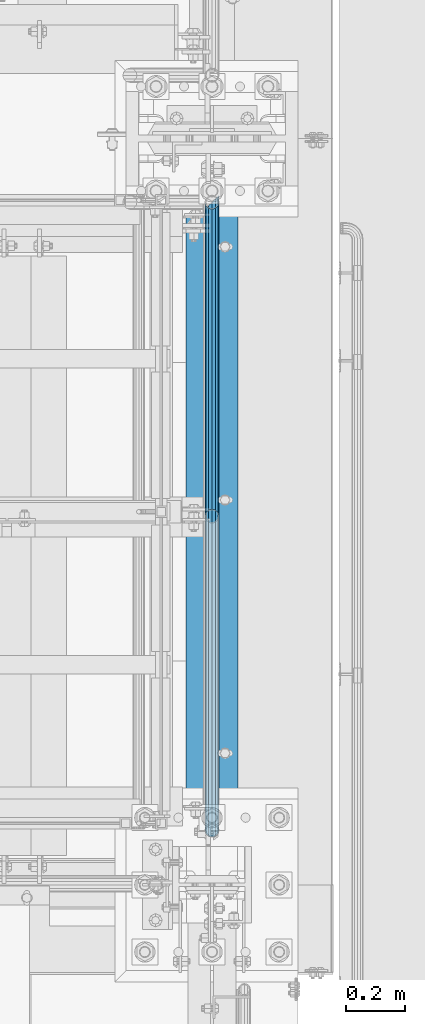
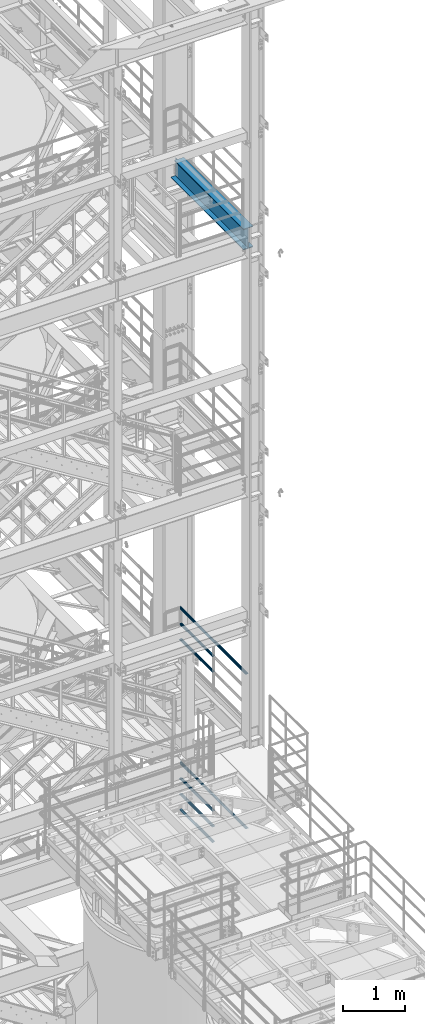
# One storey, part 1002 of 1876: 8 beams, 3 elements without a shape of their own.
"""IFC2X3 building model written with IfcOpenShell, lengths in millimetres."""

from ifc_helpers import new_model, si_unit, frame, origin_with_axes, place, context, subcontext, project, spatial, faceted_brep, material, type_object, element, aggregate, save


model = new_model("IFC2X3")

# Units and contexts
model_context = context("Model", 3, precision=1e-05, world=origin_with_axes())
body_context = subcontext(model_context, "Body", "Model", "MODEL_VIEW")
ifc_project = project(units=[si_unit("LENGTHUNIT", "METRE", prefix="MILLI"), si_unit("AREAUNIT", "SQUARE_METRE"), si_unit("VOLUMEUNIT", "CUBIC_METRE"), si_unit("MASSUNIT", "GRAM", prefix="KILO"), si_unit("TIMEUNIT", "SECOND"), si_unit("PLANEANGLEUNIT", "RADIAN"), si_unit("SOLIDANGLEUNIT", "STERADIAN"), si_unit("THERMODYNAMICTEMPERATUREUNIT", "DEGREE_CELSIUS"), si_unit("LUMINOUSINTENSITYUNIT", "LUMEN")], contexts=[model_context])

# Site, building, storey
site_placement = place(None, origin_with_axes())
site = spatial("IfcSite", under=ifc_project, at=site_placement, CompositionType="ELEMENT")
building_placement = place(site_placement, origin_with_axes())
building = spatial("IfcBuilding", under=site, at=building_placement, Name="Undefined", CompositionType="ELEMENT")
storey_placement = place(building_placement, origin_with_axes())
storey = spatial("IfcBuildingStorey", under=building, at=storey_placement, Name="Undefined", CompositionType="ELEMENT", Elevation=0.0)

# Assembly, beams
assembly_1_placement = place(storey_placement, origin_with_axes())
assembly_1 = element("IfcElementAssembly", 1, at=assembly_1_placement, inside=storey, Name="RAIL", AssemblyPlace="NOTDEFINED", PredefinedType="RIGID_FRAME")
ifc_material_1 = material()
beam_type_1 = type_object("IfcBeamType", Name="PIPE1-1/2SCH40", PredefinedType="NOTDEFINED")
beam_1_placement = place(assembly_1_placement, frame((7620.00000000001, -5857.08125, 8620.125), z_axis=(0.0, 0.0, -1.0), x_axis=(0.0, 1.0, 0.0)))
beam_1 = element("IfcBeam", 2, at=beam_1_placement, type_object=beam_type_1, material=ifc_material_1, Name="RAIL", ObjectType="PIPE1-1/2SCH40", context=body_context, shape_type="Brep", body=[
    faceted_brep([(0.0, 24.1299999999992, 0.0), (12.0650000000064, 20.8971929933177, -12.0649999999987), (12.0650000000064, 20.8971929933177, 12.0649999999987), (12.0650000000064, -20.8971929933177, 12.0649999999987), (12.0650000000064, -20.8971929933177, -12.0649999999987), (0.0, -24.1299999999992, 0.0), (20.8971929933249, -12.0650000000005, 20.8971929933177), (20.8971929933249, -12.0650000000005, 15.8661214311796), (15.2545715621445, -17.7076214311801, 10.2235000000001), (12.5151929933249, -20.4470000000001, 0.0), (15.2545715621445, -17.7076214311801, -10.2235000000001), (20.8971929933249, -12.0650000000005, -15.8661214311796), (20.8971929933249, -12.0650000000005, -20.8971929933177), (24.1300000000063, 0.0, -20.4470000000001), (24.1300000000063, 0.0, -24.130000000001), (21.3906214311868, -10.2235000000001, -17.7076214311819), (21.3906214311868, 10.2235000000001, -17.7076214311819), (20.8971929933249, 12.0650000000005, -15.8661214311796), (20.8971929933249, 12.0650000000005, -20.8971929933177), (15.2545715621445, 17.7076214311801, -10.2235000000001), (12.5151929933249, 20.4470000000001, 0.0), (15.2545715621445, 17.7076214311801, 10.2235000000001), (20.8971929933249, 12.0650000000005, 15.8661214311796), (20.8971929933249, 12.0650000000005, 20.8971929933177), (21.3906214311868, 10.2235000000001, 17.7076214311819), (24.1300000000064, 0.0, 20.4470000000001), (24.1300000000064, 0.0, 24.130000000001), (21.3906214311868, -10.2235000000001, 17.7076214311819), (1068.86375, 24.1300000000001, 0.0), (1056.79875, 20.8971929933186, -12.0649999999987), (1047.96655700668, 12.0649999999996, -20.8971929933177), (1068.86375, -24.1299999999792, 0.0), (1056.79875, -20.8971929933186, -12.0649999999987), (1056.79875, -20.8971929933186, 12.0649999999987), (1047.96655700668, -12.0649999999996, 20.8971929933177), (1047.96655700668, -12.0649999999996, -20.8971929933177), (1044.73375, 0.0, -24.130000000001), (1047.47312856881, 10.2235000000001, -17.7076214311819), (1044.73375, 0.0, -20.4470000000001), (1047.96655700668, 12.0650000000205, -15.8661214311578), (1047.96655700668, -12.0649999999787, -15.8661214312015), (1047.47312856882, -10.2235000000001, -17.7076214311819), (1053.60917843788, -17.7076214311801, -10.2235000000001), (1056.3485570067, -20.4470000000001, 0.0), (1053.60917843788, -17.7076214311801, 10.2235000000001), (1047.96655700668, -12.0649999999787, 15.8661214312015), (1047.47312856882, -10.2235000000001, 17.7076214311819), (1044.73375, 9.09494701772928e-13, 20.4470000000001), (1044.73375, 9.09494701772928e-13, 24.130000000001), (1047.96655700668, 12.0649999999996, 20.8971929933177), (1056.79875, 20.8971929933186, 12.0649999999987), (1047.96655700668, 12.0650000000205, 15.8661214311578), (1053.60917843784, 17.7076214311801, 10.2235000000001), (1056.34855700666, 20.4470000000001, 0.0), (1053.60917843784, 17.7076214311801, -10.2235000000001), (1047.47312856881, 10.2235000000001, 17.7076214311819)], [[[0, 1, 2]], [[3, 4, 5]], [[6, 7, 8, 9, 10, 11, 12, 4, 3]], [[13, 14, 12, 11, 15]], [[16, 17, 18, 14, 13]], [[2, 1, 18, 17, 19, 20, 21, 22, 23]], [[23, 22, 24, 25, 26]], [[26, 25, 27, 7, 6]], [[1, 0, 28, 29]], [[18, 1, 29, 30]], [[31, 32, 33]], [[6, 3, 33, 34]], [[3, 5, 31, 33]], [[5, 4, 32, 31]], [[4, 12, 35, 32]], [[12, 14, 36, 35]], [[14, 18, 30, 36]], [[37, 38, 36, 30, 39]], [[40, 35, 36, 38, 41]], [[33, 32, 35, 40, 42, 43, 44, 45, 34]], [[34, 45, 46, 47, 48]], [[26, 6, 34, 48]], [[2, 23, 49, 50]], [[23, 26, 48, 49]], [[0, 2, 50, 28]], [[28, 50, 29]], [[49, 51, 52, 53, 54, 39, 30, 29, 50]], [[48, 47, 55, 51, 49]], [[25, 24, 55, 47]], [[55, 24, 22, 21, 52, 51]], [[21, 20, 53, 52]], [[20, 19, 54, 53]], [[19, 17, 16, 37, 39, 54]], [[16, 13, 38, 37]], [[13, 15, 41, 38]], [[41, 15, 11, 10, 42, 40]], [[10, 9, 43, 42]], [[9, 8, 44, 43]], [[8, 7, 27, 46, 45, 44]], [[27, 25, 47, 46]]]),
])
beam_2_placement = place(assembly_1_placement, frame((7620.00000000001, -5857.08125, 8924.925), z_axis=(0.0, 0.0, -1.0), x_axis=(0.0, 1.0, 0.0)))
beam_2 = element("IfcBeam", 3, at=beam_2_placement, type_object=beam_type_1, material=ifc_material_1, Name="RAIL", ObjectType="PIPE1-1/2SCH40", context=body_context, shape_type="Brep", body=[
    faceted_brep([(0.0, 24.1299999999992, 0.0), (12.0650000000064, 20.8971929933177, -12.0649999999987), (12.0650000000064, 20.8971929933177, 12.0649999999987), (12.0650000000064, -20.8971929933177, 12.0649999999987), (12.0650000000064, -20.8971929933177, -12.0649999999987), (0.0, -24.1299999999992, 0.0), (20.8971929933249, -12.0650000000005, 20.8971929933177), (20.8971929933249, -12.0650000000005, 15.8661214311796), (15.2545715621445, -17.7076214311801, 10.2235000000001), (12.5151929933249, -20.4470000000001, 0.0), (15.2545715621445, -17.7076214311801, -10.2235000000001), (20.8971929933249, -12.0650000000005, -15.8661214311796), (20.8971929933249, -12.0650000000005, -20.8971929933177), (24.1300000000063, 0.0, -20.4470000000001), (24.1300000000063, 0.0, -24.130000000001), (21.3906214311868, -10.2235000000001, -17.7076214311819), (21.3906214311868, 10.2235000000001, -17.7076214311819), (20.8971929933249, 12.0650000000005, -15.8661214311796), (20.8971929933249, 12.0650000000005, -20.8971929933177), (15.2545715621445, 17.7076214311801, -10.2235000000001), (12.5151929933249, 20.4470000000001, 0.0), (15.2545715621445, 17.7076214311801, 10.2235000000001), (20.8971929933249, 12.0650000000005, 15.8661214311796), (20.8971929933249, 12.0650000000005, 20.8971929933177), (21.3906214311868, 10.2235000000001, 17.7076214311819), (24.1300000000064, 0.0, 20.4470000000001), (24.1300000000064, 0.0, 24.130000000001), (21.3906214311868, -10.2235000000001, 17.7076214311819), (1068.86375, 24.1300000000001, 0.0), (1056.79875, 20.8971929933186, -12.0649999999987), (1047.96655700668, 12.0649999999996, -20.8971929933177), (1068.86375, -24.1299999999792, 0.0), (1056.79875, -20.8971929933186, -12.0649999999987), (1056.79875, -20.8971929933186, 12.0649999999987), (1047.96655700668, -12.0649999999996, 20.8971929933177), (1047.96655700668, -12.0649999999996, -20.8971929933177), (1044.73375, 0.0, -24.130000000001), (1047.47312856881, 10.2235000000001, -17.7076214311819), (1044.73375, 0.0, -20.4470000000001), (1047.96655700668, 12.0650000000205, -15.8661214311578), (1047.96655700668, -12.0649999999787, -15.8661214312015), (1047.47312856882, -10.2235000000001, -17.7076214311819), (1053.60917843788, -17.7076214311801, -10.2235000000001), (1056.3485570067, -20.4470000000001, 0.0), (1053.60917843788, -17.7076214311801, 10.2235000000001), (1047.96655700668, -12.0649999999787, 15.8661214312015), (1047.47312856882, -10.2235000000001, 17.7076214311819), (1044.73375, 9.09494701772928e-13, 20.4470000000001), (1044.73375, 9.09494701772928e-13, 24.130000000001), (1047.96655700668, 12.0649999999996, 20.8971929933177), (1056.79875, 20.8971929933186, 12.0649999999987), (1047.96655700668, 12.0650000000205, 15.8661214311578), (1053.60917843784, 17.7076214311801, 10.2235000000001), (1056.34855700666, 20.4470000000001, 0.0), (1053.60917843784, 17.7076214311801, -10.2235000000001), (1047.47312856881, 10.2235000000001, 17.7076214311819)], [[[0, 1, 2]], [[3, 4, 5]], [[6, 7, 8, 9, 10, 11, 12, 4, 3]], [[13, 14, 12, 11, 15]], [[16, 17, 18, 14, 13]], [[2, 1, 18, 17, 19, 20, 21, 22, 23]], [[23, 22, 24, 25, 26]], [[26, 25, 27, 7, 6]], [[1, 0, 28, 29]], [[18, 1, 29, 30]], [[31, 32, 33]], [[6, 3, 33, 34]], [[3, 5, 31, 33]], [[5, 4, 32, 31]], [[4, 12, 35, 32]], [[12, 14, 36, 35]], [[14, 18, 30, 36]], [[37, 38, 36, 30, 39]], [[40, 35, 36, 38, 41]], [[33, 32, 35, 40, 42, 43, 44, 45, 34]], [[34, 45, 46, 47, 48]], [[26, 6, 34, 48]], [[2, 23, 49, 50]], [[23, 26, 48, 49]], [[0, 2, 50, 28]], [[28, 50, 29]], [[49, 51, 52, 53, 54, 39, 30, 29, 50]], [[48, 47, 55, 51, 49]], [[25, 24, 55, 47]], [[55, 24, 22, 21, 52, 51]], [[21, 20, 53, 52]], [[20, 19, 54, 53]], [[19, 17, 16, 37, 39, 54]], [[16, 13, 38, 37]], [[13, 15, 41, 38]], [[41, 15, 11, 10, 42, 40]], [[10, 9, 43, 42]], [[9, 8, 44, 43]], [[8, 7, 27, 46, 45, 44]], [[27, 25, 47, 46]]]),
])
beam_3_placement = place(assembly_1_placement, frame((7620.00000000001, -6950.075, 9229.725), z_axis=(0.0, 0.0, -1.0), x_axis=(0.0, 1.0, 0.0)))
beam_3 = element("IfcBeam", 4, at=beam_3_placement, type_object=beam_type_1, material=ifc_material_1, Name="RAIL", ObjectType="PIPE1-1/2SCH40", context=body_context, shape_type="Brep", body=[
    faceted_brep([(24.1300000000001, -20.4469999999999, 0.0), (34.3535000000002, -17.7076214311803, 10.2235000000001), (2144.14987856882, -17.7076214311801, 10.2235000000001), (2141.4105, -20.4470000000001, 0.0), (41.8376214311802, -10.2235000000001, 17.7076214311819), (2151.634, -10.2235000000001, 17.7076214311819), (44.5770000000002, 0.0, 20.4470000000001), (2161.8575, 0.0, 20.4470000000001), (41.8376214311802, 10.2235000000001, 17.7076214311819), (2172.081, 10.2235000000001, 17.7076214311819), (34.3535000000002, 17.7076214311803, 10.2235000000001), (2179.56512143118, 17.7076214311801, 10.2235000000001), (24.1300000000001, 20.4469999999999, 0.0), (2182.3045, 20.4470000000001, 0.0), (13.9065000000001, 17.7076214311803, -10.2235000000001), (2179.56512143118, 17.7076214311801, -10.2235000000001), (6.42237856882002, 10.2235000000001, -17.7076214311819), (2172.081, 10.2235000000001, -17.7076214311819), (3.68299999999999, 0.0, -20.4470000000001), (2161.8575, 0.0, -20.4470000000001), (6.42237856882002, -10.2235000000001, -17.7076214311819), (2151.634, -10.2235000000001, -17.7076214311819), (13.9065000000001, -17.7076214311803, -10.2235000000001), (2144.14987856882, -17.7076214311801, -10.2235000000001), (24.1299999999854, -24.1299999999992, 0.0), (12.0650000000064, -20.8971929933177, -12.0649999999987), (2140.96030700668, -20.8971929933186, -12.0649999999987), (2137.7275, -24.1300000000001, 0.0), (3.23280700668147, -12.0650000000001, -20.8971929933177), (2149.7925, -12.0649999999996, -20.8971929933177), (-1.45519152283669e-11, 0.0, -24.130000000001), (2161.8575, 0.0, -24.130000000001), (3.23280700668147, 12.0650000000001, -20.8971929933177), (2173.9225, 12.0649999999996, -20.8971929933177), (12.0650000000064, 20.8971929933177, -12.0649999999987), (2182.75469299332, 20.8971929933186, -12.0649999999987), (24.1300000000047, 24.1299999999992, 0.0), (2185.9875, 24.1300000000001, 0.0), (36.1949999999997, 20.8971929933184, 12.0649999999987), (2182.75469299332, 20.8971929933186, 12.0649999999987), (45.0271929933187, 12.0650000000001, 20.8971929933177), (2173.9225, 12.0649999999996, 20.8971929933177), (48.2600000000002, 0.0, 24.130000000001), (2161.8575, 0.0, 24.130000000001), (45.0271929933187, -12.0650000000001, 20.8971929933177), (2149.7925, -12.0649999999996, 20.8971929933177), (36.1949999999997, -20.8971929933184, 12.0649999999987), (2140.96030700668, -20.8971929933186, 12.0649999999987)], [[[0, 1, 2, 3]], [[1, 4, 5, 2]], [[4, 6, 7, 5]], [[6, 8, 9, 7]], [[8, 10, 11, 9]], [[10, 12, 13, 11]], [[12, 14, 15, 13]], [[14, 16, 17, 15]], [[16, 18, 19, 17]], [[18, 20, 21, 19]], [[20, 22, 23, 21]], [[22, 0, 3, 23]], [[24, 25, 26, 27]], [[25, 28, 29, 26]], [[28, 30, 31, 29]], [[30, 32, 33, 31]], [[32, 34, 35, 33]], [[34, 36, 37, 35]], [[36, 38, 39, 37]], [[38, 40, 41, 39]], [[40, 42, 43, 41]], [[42, 44, 45, 43]], [[44, 46, 47, 45]], [[46, 24, 27, 47]], [[29, 31, 33, 35, 37, 39, 41, 43, 45, 47, 27, 26], [5, 7, 9, 11, 13, 15, 17, 19, 21, 23, 3, 2]], [[46, 44, 42, 40, 38, 36, 34, 32, 30, 28, 25, 24], [22, 20, 18, 16, 14, 12, 10, 8, 6, 4, 1, 0]]]),
])
aggregate(assembly_1, [beam_1, beam_2, beam_3])

assembly_2_placement = place(storey_placement, origin_with_axes())
assembly_2 = element("IfcElementAssembly", 5, at=assembly_2_placement, inside=storey, Name="RAIL", AssemblyPlace="NOTDEFINED", PredefinedType="RIGID_FRAME")
beam_4_placement = place(assembly_2_placement, frame((7620.0, -4788.2175, 5292.725), z_axis=(0.0, 0.0, 1.0), x_axis=(0.0, -1.0, 0.0)))
beam_4 = element("IfcBeam", 6, at=beam_4_placement, type_object=beam_type_1, material=ifc_material_1, Name="RAIL", ObjectType="PIPE1-1/2SCH40", context=body_context, shape_type="Brep", body=[
    faceted_brep([(1047.96655700668, -12.0649999999996, 20.8971929933177), (1047.96655700668, -12.0649999999787, 15.8661214312015), (1047.47312856882, -10.2235000000001, 17.7076214311819), (1044.73375, 9.09494701772928e-13, 20.4470000000001), (1044.73375, 9.09494701772928e-13, 24.130000000001), (1047.47312856881, 10.2235000000001, 17.7076214311819), (1047.96655700668, 12.0650000000205, 15.8661214311578), (1047.96655700668, 12.0649999999996, 20.8971929933177), (1068.86375, 24.1300000000001, 0.0), (1056.79875, 20.8971929933186, 12.0649999999987), (1056.79875, 20.8971929933186, -12.0649999999987), (1053.60917843784, 17.7076214311801, 10.2235000000001), (1056.34855700666, 20.4470000000001, 0.0), (1053.60917843784, 17.7076214311801, -10.2235000000001), (1047.96655700668, 12.0650000000205, -15.8661214311578), (1047.96655700668, 12.0649999999996, -20.8971929933177), (1047.47312856881, 10.2235000000001, -17.7076214311819), (1044.73375, 0.0, -20.4470000000001), (1044.73375, 0.0, -24.130000000001), (1047.96655700668, -12.0649999999787, -15.8661214312015), (1047.96655700668, -12.0649999999996, -20.8971929933177), (1047.47312856882, -10.2235000000001, -17.7076214311819), (1068.86375, -24.1299999999792, 0.0), (1056.79875, -20.8971929933186, -12.0649999999987), (1056.79875, -20.8971929933186, 12.0649999999987), (1053.60917843788, -17.7076214311801, -10.2235000000001), (1056.3485570067, -20.4470000000001, 0.0), (1053.60917843788, -17.7076214311801, 10.2235000000001), (12.0650000000064, -20.8971929933177, -12.0649999999987), (20.8971929933249, -12.0650000000005, -20.8971929933177), (0.0, 24.1299999999992, 0.0), (12.0650000000064, 20.8971929933177, -12.0649999999987), (12.0650000000064, 20.8971929933177, 12.0649999999987), (20.8971929933249, 12.0650000000005, 20.8971929933177), (24.1300000000064, 0.0, 24.130000000001), (20.8971929933249, 12.0650000000005, -20.8971929933177), (24.1300000000063, 0.0, -24.130000000001), (24.1300000000063, 0.0, -20.4470000000001), (20.8971929933249, -12.0650000000005, -15.8661214311796), (21.3906214311868, -10.2235000000001, -17.7076214311819), (21.3906214311868, 10.2235000000001, -17.7076214311819), (20.8971929933249, 12.0650000000005, -15.8661214311796), (15.2545715621445, 17.7076214311801, -10.2235000000001), (12.5151929933249, 20.4470000000001, 0.0), (15.2545715621445, 17.7076214311801, 10.2235000000001), (20.8971929933249, 12.0650000000005, 15.8661214311796), (21.3906214311868, 10.2235000000001, 17.7076214311819), (24.1300000000064, 0.0, 20.4470000000001), (21.3906214311868, -10.2235000000001, 17.7076214311819), (20.8971929933249, -12.0650000000005, 15.8661214311796), (20.8971929933249, -12.0650000000005, 20.8971929933177), (12.0650000000064, -20.8971929933177, 12.0649999999987), (0.0, -24.1299999999992, 0.0), (15.2545715621445, -17.7076214311801, 10.2235000000001), (12.5151929933249, -20.4470000000001, 0.0), (15.2545715621445, -17.7076214311801, -10.2235000000001)], [[[0, 1, 2, 3, 4]], [[4, 3, 5, 6, 7]], [[8, 9, 10]], [[7, 6, 11, 12, 13, 14, 15, 10, 9]], [[16, 17, 18, 15, 14]], [[19, 20, 18, 17, 21]], [[22, 23, 24]], [[24, 23, 20, 19, 25, 26, 27, 1, 0]], [[28, 29, 20, 23]], [[30, 31, 32]], [[33, 34, 4, 7]], [[32, 33, 7, 9]], [[30, 32, 9, 8]], [[31, 30, 8, 10]], [[35, 31, 10, 15]], [[36, 35, 15, 18]], [[29, 36, 18, 20]], [[37, 36, 29, 38, 39]], [[40, 41, 35, 36, 37]], [[32, 31, 35, 41, 42, 43, 44, 45, 33]], [[33, 45, 46, 47, 34]], [[34, 47, 48, 49, 50]], [[34, 50, 0, 4]], [[50, 51, 24, 0]], [[51, 52, 22, 24]], [[52, 28, 23, 22]], [[51, 28, 52]], [[50, 49, 53, 54, 55, 38, 29, 28, 51]], [[55, 54, 26, 25]], [[21, 39, 38, 55, 25, 19]], [[37, 39, 21, 17]], [[40, 37, 17, 16]], [[42, 41, 40, 16, 14, 13]], [[43, 42, 13, 12]], [[44, 43, 12, 11]], [[5, 46, 45, 44, 11, 6]], [[47, 46, 5, 3]], [[48, 47, 3, 2]], [[53, 49, 48, 2, 1, 27]], [[54, 53, 27, 26]]]),
])
beam_5_placement = place(assembly_2_placement, frame((7619.99999999923, -5857.08125, 5597.52500110399), z_axis=(0.0, 0.0, -1.0), x_axis=(0.0, 1.0, 0.0)))
beam_5 = element("IfcBeam", 7, at=beam_5_placement, type_object=beam_type_1, material=ifc_material_1, Name="RAIL", ObjectType="PIPE1-1/2SCH40", context=body_context, shape_type="Brep", body=[
    faceted_brep([(0.0, 24.1299999999992, 0.0), (12.0650000000064, 20.8971929933177, -12.0649999999987), (12.0650000000064, 20.8971929933177, 12.0649999999987), (12.0650000000064, -20.8971929933177, 12.0649999999987), (12.0650000000064, -20.8971929933177, -12.0649999999987), (0.0, -24.1299999999992, 0.0), (20.8971929933249, -12.0650000000005, 20.8971929933177), (20.8971929933249, -12.0650000000005, 15.8661214311796), (15.2545715621445, -17.7076214311801, 10.2235000000001), (12.5151929933249, -20.4470000000001, 0.0), (15.2545715621445, -17.7076214311801, -10.2235000000001), (20.8971929933249, -12.0650000000005, -15.8661214311796), (20.8971929933249, -12.0650000000005, -20.8971929933177), (24.1300000000063, 0.0, -20.4470000000001), (24.1300000000063, 0.0, -24.130000000001), (21.3906214311868, -10.2235000000001, -17.7076214311819), (21.3906214311868, 10.2235000000001, -17.7076214311819), (20.8971929933249, 12.0650000000005, -15.8661214311796), (20.8971929933249, 12.0650000000005, -20.8971929933177), (15.2545715621445, 17.7076214311801, -10.2235000000001), (12.5151929933249, 20.4470000000001, 0.0), (15.2545715621445, 17.7076214311801, 10.2235000000001), (20.8971929933249, 12.0650000000005, 15.8661214311796), (20.8971929933249, 12.0650000000005, 20.8971929933177), (21.3906214311868, 10.2235000000001, 17.7076214311819), (24.1300000000064, 0.0, 20.4470000000001), (24.1300000000064, 0.0, 24.130000000001), (21.3906214311868, -10.2235000000001, 17.7076214311819), (1068.86375, 24.1300000000001, 0.0), (1056.79875, 20.8971929933186, -12.0649999999987), (1047.96655700668, 12.0649999999996, -20.8971929933177), (1068.86375, -24.1299999999792, 0.0), (1056.79875, -20.8971929933186, -12.0649999999987), (1056.79875, -20.8971929933186, 12.0649999999987), (1047.96655700668, -12.0649999999996, 20.8971929933177), (1047.96655700668, -12.0649999999996, -20.8971929933177), (1044.73375, 0.0, -24.130000000001), (1047.47312856881, 10.2235000000001, -17.7076214311819), (1044.73375, 0.0, -20.4470000000001), (1047.96655700668, 12.0650000000205, -15.8661214311578), (1047.96655700668, -12.0649999999787, -15.8661214312015), (1047.47312856882, -10.2235000000001, -17.7076214311819), (1053.60917843788, -17.7076214311801, -10.2235000000001), (1056.3485570067, -20.4470000000001, 0.0), (1053.60917843788, -17.7076214311801, 10.2235000000001), (1047.96655700668, -12.0649999999787, 15.8661214312015), (1047.47312856882, -10.2235000000001, 17.7076214311819), (1044.73375, 9.09494701772928e-13, 20.4470000000001), (1044.73375, 9.09494701772928e-13, 24.130000000001), (1047.96655700668, 12.0649999999996, 20.8971929933177), (1056.79875, 20.8971929933186, 12.0649999999987), (1047.96655700668, 12.0650000000205, 15.8661214311578), (1053.60917843784, 17.7076214311801, 10.2235000000001), (1056.34855700666, 20.4470000000001, 0.0), (1053.60917843784, 17.7076214311801, -10.2235000000001), (1047.47312856881, 10.2235000000001, 17.7076214311819)], [[[0, 1, 2]], [[3, 4, 5]], [[6, 7, 8, 9, 10, 11, 12, 4, 3]], [[13, 14, 12, 11, 15]], [[16, 17, 18, 14, 13]], [[2, 1, 18, 17, 19, 20, 21, 22, 23]], [[23, 22, 24, 25, 26]], [[26, 25, 27, 7, 6]], [[1, 0, 28, 29]], [[18, 1, 29, 30]], [[31, 32, 33]], [[6, 3, 33, 34]], [[3, 5, 31, 33]], [[5, 4, 32, 31]], [[4, 12, 35, 32]], [[12, 14, 36, 35]], [[14, 18, 30, 36]], [[37, 38, 36, 30, 39]], [[40, 35, 36, 38, 41]], [[33, 32, 35, 40, 42, 43, 44, 45, 34]], [[34, 45, 46, 47, 48]], [[26, 6, 34, 48]], [[2, 23, 49, 50]], [[23, 26, 48, 49]], [[0, 2, 50, 28]], [[28, 50, 29]], [[49, 51, 52, 53, 54, 39, 30, 29, 50]], [[48, 47, 55, 51, 49]], [[25, 24, 55, 47]], [[55, 24, 22, 21, 52, 51]], [[21, 20, 53, 52]], [[20, 19, 54, 53]], [[19, 17, 16, 37, 39, 54]], [[16, 13, 38, 37]], [[13, 15, 41, 38]], [[41, 15, 11, 10, 42, 40]], [[10, 9, 43, 42]], [[9, 8, 44, 43]], [[8, 7, 27, 46, 45, 44]], [[27, 25, 47, 46]]]),
])
beam_6_placement = place(assembly_2_placement, frame((7619.99999999959, -5857.08125, 5902.32500110437), z_axis=(0.0, 0.0, -1.0), x_axis=(0.0, 1.0, 0.0)))
beam_6 = element("IfcBeam", 8, at=beam_6_placement, type_object=beam_type_1, material=ifc_material_1, Name="RAIL", ObjectType="PIPE1-1/2SCH40", context=body_context, shape_type="Brep", body=[
    faceted_brep([(0.0, 24.1299999999992, 0.0), (12.0650000000064, 20.8971929933177, -12.0649999999987), (12.0650000000064, 20.8971929933177, 12.0649999999987), (12.0650000000064, -20.8971929933177, 12.0649999999987), (12.0650000000064, -20.8971929933177, -12.0649999999987), (0.0, -24.1299999999992, 0.0), (20.8971929933249, -12.0650000000005, 20.8971929933177), (20.8971929933249, -12.0650000000005, 15.8661214311796), (15.2545715621445, -17.7076214311801, 10.2235000000001), (12.5151929933249, -20.4470000000001, 0.0), (15.2545715621445, -17.7076214311801, -10.2235000000001), (20.8971929933249, -12.0650000000005, -15.8661214311796), (20.8971929933249, -12.0650000000005, -20.8971929933177), (24.1300000000063, 0.0, -20.4470000000001), (24.1300000000063, 0.0, -24.130000000001), (21.3906214311868, -10.2235000000001, -17.7076214311819), (21.3906214311868, 10.2235000000001, -17.7076214311819), (20.8971929933249, 12.0650000000005, -15.8661214311796), (20.8971929933249, 12.0650000000005, -20.8971929933177), (15.2545715621445, 17.7076214311801, -10.2235000000001), (12.5151929933249, 20.4470000000001, 0.0), (15.2545715621445, 17.7076214311801, 10.2235000000001), (20.8971929933249, 12.0650000000005, 15.8661214311796), (20.8971929933249, 12.0650000000005, 20.8971929933177), (21.3906214311868, 10.2235000000001, 17.7076214311819), (24.1300000000064, 0.0, 20.4470000000001), (24.1300000000064, 0.0, 24.130000000001), (21.3906214311868, -10.2235000000001, 17.7076214311819), (1068.86375, 24.1300000000001, 0.0), (1056.79875, 20.8971929933186, -12.0649999999987), (1047.96655700668, 12.0649999999996, -20.8971929933177), (1068.86375, -24.1299999999792, 0.0), (1056.79875, -20.8971929933186, -12.0649999999987), (1056.79875, -20.8971929933186, 12.0649999999987), (1047.96655700668, -12.0649999999996, 20.8971929933177), (1047.96655700668, -12.0649999999996, -20.8971929933177), (1044.73375, 0.0, -24.130000000001), (1047.47312856881, 10.2235000000001, -17.7076214311819), (1044.73375, 0.0, -20.4470000000001), (1047.96655700668, 12.0650000000205, -15.8661214311578), (1047.96655700668, -12.0649999999787, -15.8661214312015), (1047.47312856882, -10.2235000000001, -17.7076214311819), (1053.60917843788, -17.7076214311801, -10.2235000000001), (1056.3485570067, -20.4470000000001, 0.0), (1053.60917843788, -17.7076214311801, 10.2235000000001), (1047.96655700668, -12.0649999999787, 15.8661214312015), (1047.47312856882, -10.2235000000001, 17.7076214311819), (1044.73375, 9.09494701772928e-13, 20.4470000000001), (1044.73375, 9.09494701772928e-13, 24.130000000001), (1047.96655700668, 12.0649999999996, 20.8971929933177), (1056.79875, 20.8971929933186, 12.0649999999987), (1047.96655700668, 12.0650000000205, 15.8661214311578), (1053.60917843784, 17.7076214311801, 10.2235000000001), (1056.34855700666, 20.4470000000001, 0.0), (1053.60917843784, 17.7076214311801, -10.2235000000001), (1047.47312856881, 10.2235000000001, 17.7076214311819)], [[[0, 1, 2]], [[3, 4, 5]], [[6, 7, 8, 9, 10, 11, 12, 4, 3]], [[13, 14, 12, 11, 15]], [[16, 17, 18, 14, 13]], [[2, 1, 18, 17, 19, 20, 21, 22, 23]], [[23, 22, 24, 25, 26]], [[26, 25, 27, 7, 6]], [[1, 0, 28, 29]], [[18, 1, 29, 30]], [[31, 32, 33]], [[6, 3, 33, 34]], [[3, 5, 31, 33]], [[5, 4, 32, 31]], [[4, 12, 35, 32]], [[12, 14, 36, 35]], [[14, 18, 30, 36]], [[37, 38, 36, 30, 39]], [[40, 35, 36, 38, 41]], [[33, 32, 35, 40, 42, 43, 44, 45, 34]], [[34, 45, 46, 47, 48]], [[26, 6, 34, 48]], [[2, 23, 49, 50]], [[23, 26, 48, 49]], [[0, 2, 50, 28]], [[28, 50, 29]], [[49, 51, 52, 53, 54, 39, 30, 29, 50]], [[48, 47, 55, 51, 49]], [[25, 24, 55, 47]], [[55, 24, 22, 21, 52, 51]], [[21, 20, 53, 52]], [[20, 19, 54, 53]], [[19, 17, 16, 37, 39, 54]], [[16, 13, 38, 37]], [[13, 15, 41, 38]], [[41, 15, 11, 10, 42, 40]], [[10, 9, 43, 42]], [[9, 8, 44, 43]], [[8, 7, 27, 46, 45, 44]], [[27, 25, 47, 46]]]),
])
beam_7_placement = place(assembly_2_placement, frame((7620.00000000063, -6950.07500000001, 6207.12499997672), z_axis=(0.0, 0.0, -1.0), x_axis=(0.0, 1.0, 0.0)))
beam_7 = element("IfcBeam", 9, at=beam_7_placement, type_object=beam_type_1, material=ifc_material_1, Name="RAIL", ObjectType="PIPE1-1/2SCH40", context=body_context, shape_type="Brep", body=[
    faceted_brep([(24.1300000000001, -20.4469999999999, 0.0), (34.3535000000002, -17.7076214311803, 10.2235000000001), (2144.14987856882, -17.7076214311801, 10.2235000000001), (2141.4105, -20.4470000000001, 0.0), (41.8376214311802, -10.2235000000001, 17.7076214311819), (2151.634, -10.2235000000001, 17.7076214311819), (44.5770000000002, 0.0, 20.4470000000001), (2161.8575, 0.0, 20.4470000000001), (41.8376214311802, 10.2235000000001, 17.7076214311819), (2172.081, 10.2235000000001, 17.7076214311819), (34.3535000000002, 17.7076214311803, 10.2235000000001), (2179.56512143118, 17.7076214311801, 10.2235000000001), (24.1300000000001, 20.4469999999999, 0.0), (2182.3045, 20.4470000000001, 0.0), (13.9065000000001, 17.7076214311803, -10.2235000000001), (2179.56512143118, 17.7076214311801, -10.2235000000001), (6.42237856882002, 10.2235000000001, -17.7076214311819), (2172.081, 10.2235000000001, -17.7076214311819), (3.68299999999999, 0.0, -20.4470000000001), (2161.8575, 0.0, -20.4470000000001), (6.42237856882002, -10.2235000000001, -17.7076214311819), (2151.634, -10.2235000000001, -17.7076214311819), (13.9065000000001, -17.7076214311803, -10.2235000000001), (2144.14987856882, -17.7076214311801, -10.2235000000001), (24.1299999999854, -24.1299999999992, 0.0), (12.0650000000064, -20.8971929933177, -12.0649999999987), (2140.96030700668, -20.8971929933186, -12.0649999999987), (2137.7275, -24.1300000000001, 0.0), (3.23280700668147, -12.0650000000001, -20.8971929933177), (2149.7925, -12.0649999999996, -20.8971929933177), (-1.45519152283669e-11, 0.0, -24.130000000001), (2161.8575, 0.0, -24.130000000001), (3.23280700668147, 12.0650000000001, -20.8971929933177), (2173.9225, 12.0649999999996, -20.8971929933177), (12.0650000000064, 20.8971929933177, -12.0649999999987), (2182.75469299332, 20.8971929933186, -12.0649999999987), (24.1300000000047, 24.1299999999992, 0.0), (2185.9875, 24.1300000000001, 0.0), (36.1949999999997, 20.8971929933184, 12.0649999999987), (2182.75469299332, 20.8971929933186, 12.0649999999987), (45.0271929933187, 12.0650000000001, 20.8971929933177), (2173.9225, 12.0649999999996, 20.8971929933177), (48.2600000000002, 0.0, 24.130000000001), (2161.8575, 0.0, 24.130000000001), (45.0271929933187, -12.0650000000001, 20.8971929933177), (2149.7925, -12.0649999999996, 20.8971929933177), (36.1949999999997, -20.8971929933184, 12.0649999999987), (2140.96030700668, -20.8971929933186, 12.0649999999987)], [[[0, 1, 2, 3]], [[1, 4, 5, 2]], [[4, 6, 7, 5]], [[6, 8, 9, 7]], [[8, 10, 11, 9]], [[10, 12, 13, 11]], [[12, 14, 15, 13]], [[14, 16, 17, 15]], [[16, 18, 19, 17]], [[18, 20, 21, 19]], [[20, 22, 23, 21]], [[22, 0, 3, 23]], [[24, 25, 26, 27]], [[25, 28, 29, 26]], [[28, 30, 31, 29]], [[30, 32, 33, 31]], [[32, 34, 35, 33]], [[34, 36, 37, 35]], [[36, 38, 39, 37]], [[38, 40, 41, 39]], [[40, 42, 43, 41]], [[42, 44, 45, 43]], [[44, 46, 47, 45]], [[46, 24, 27, 47]], [[29, 31, 33, 35, 37, 39, 41, 43, 45, 47, 27, 26], [5, 7, 9, 11, 13, 15, 17, 19, 21, 23, 3, 2]], [[46, 44, 42, 40, 38, 36, 34, 32, 30, 28, 25, 24], [22, 20, 18, 16, 14, 12, 10, 8, 6, 4, 1, 0]]]),
])
aggregate(assembly_2, [beam_4, beam_5, beam_6, beam_7])

# Assembly, beam
assembly_3_placement = place(storey_placement, origin_with_axes())
assembly_3 = element("IfcElementAssembly", 10, at=assembly_3_placement, inside=storey, Name="BEAM", AssemblyPlace="NOTDEFINED", PredefinedType="RIGID_FRAME")
ifc_material_2 = material(Name="STEEL/A992")
beam_type_2 = type_object("IfcBeamType", Name="W16X45", PredefinedType="NOTDEFINED")
beam_8_placement = place(assembly_3_placement, frame((7620.0, -7112.0, 17778.4125), z_axis=(0.0, 0.0, 1.0), x_axis=(0.0, 1.0, 0.0)))
beam_8 = element("IfcBeam", 11, at=beam_8_placement, type_object=beam_type_2, material=ifc_material_2, Name="BEAM", ObjectType="W16X45", context=body_context, shape_type="Brep", body=[
    faceted_brep([(2362.99375, -88.8999999999996, 204.787499999999), (2362.99375, -88.8999999999996, 190.5), (2362.99375, -4.76249999999982, 190.5), (2362.99375, -4.76249999999982, 166.427501487731), (2362.99375, 4.76249999999982, 166.427501487731), (2362.99375, 4.76249999999982, 190.5), (2362.99375, 88.8999999999996, 190.5), (2362.99375, 88.8999999999996, 204.787499999999), (2363.96047992259, -4.76249999999982, 161.567421969685), (2363.96047992259, 4.76249999999982, 161.567421969685), (2366.71349382307, -4.76249999999982, 157.447245501531), (2366.71349382307, 4.76249999999982, 157.447245501531), (2370.83367029122, -4.76249999999982, 154.694231601054), (2370.83367029122, 4.76249999999982, 154.694231601054), (2375.69374980926, -4.76249999999982, 153.727501678466), (2375.69374980926, 4.76249999999982, 153.727501678466), (2477.29375, -4.76249999999982, 153.727501678466), (2477.29375, 4.76249999999982, 153.727501678466), (142.875, -88.8999999999996, -204.787499999999), (142.875, -88.8999999999996, -190.5), (142.875, -4.76249999999982, -190.5), (142.875, -4.76249999999982, 190.5), (142.875, -88.8999999999996, 190.5), (142.875, -88.8999999999996, 204.787499999999), (142.875, 88.8999999999996, 204.787499999999), (142.875, 88.8999999999996, 190.5), (142.875, 4.76249999999982, 190.5), (142.875, 4.76249999999982, -190.5), (142.875, 88.8999999999996, -190.5), (142.875, 88.8999999999996, -204.787499999999), (2477.29375, 4.76249999999982, -190.5), (2477.29375, 88.8999999999996, -190.5), (2477.29375, 88.8999999999996, -204.787499999999), (2477.29375, -88.8999999999996, -204.787499999999), (2477.29375, -88.8999999999996, -190.5), (2477.29375, -4.76249999999982, -190.5)], [[[0, 1, 2, 3, 4, 5, 6, 7]], [[8, 9, 4, 3]], [[10, 11, 9, 8]], [[12, 13, 11, 10]], [[14, 15, 13, 12]], [[16, 17, 15, 14]], [[18, 19, 20, 21, 22, 23, 24, 25, 26, 27, 28, 29]], [[28, 27, 30, 31]], [[29, 28, 31, 32]], [[18, 29, 32, 33]], [[19, 18, 33, 34]], [[20, 19, 34, 35]], [[12, 10, 8, 3, 2, 21, 20, 35, 16, 14]], [[22, 21, 2, 1]], [[23, 22, 1, 0]], [[24, 23, 0, 7]], [[25, 24, 7, 6]], [[26, 25, 6, 5]], [[30, 27, 26, 5, 4, 9, 11, 13, 15, 17]], [[35, 34, 33, 32, 31, 30, 17, 16]]]),
])
aggregate(assembly_3, [beam_8])

save(model, "model.ifc")
